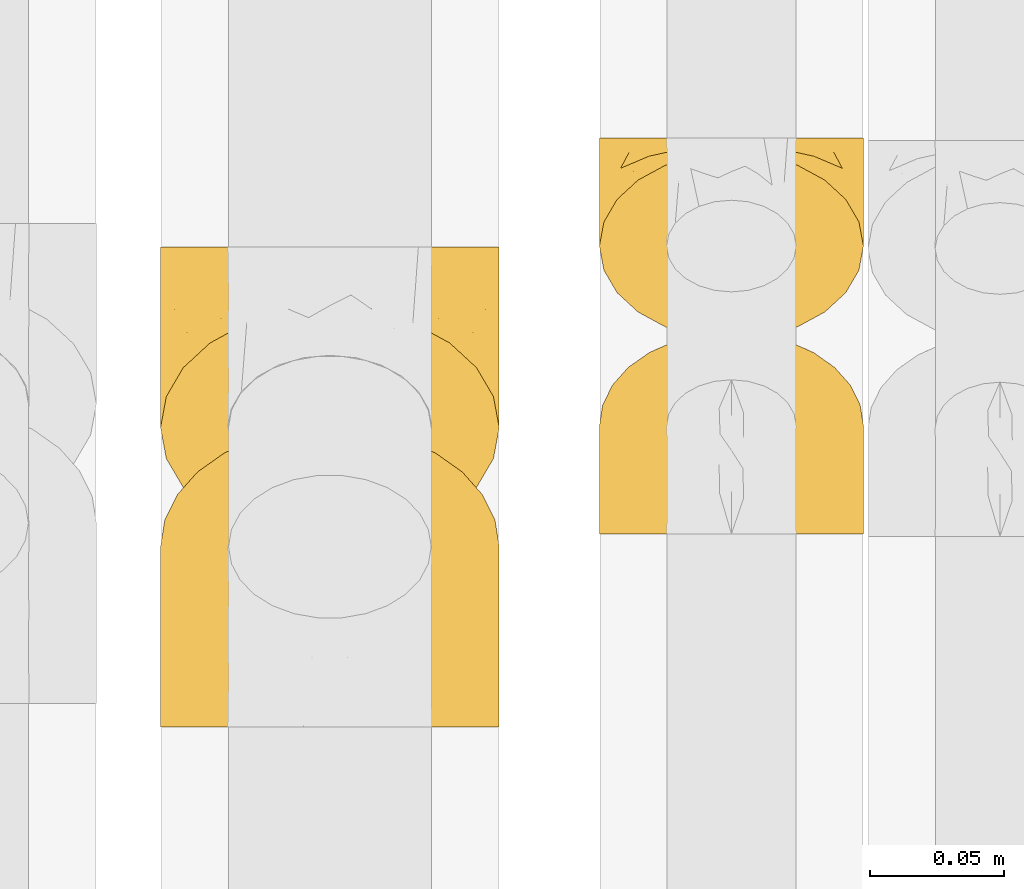
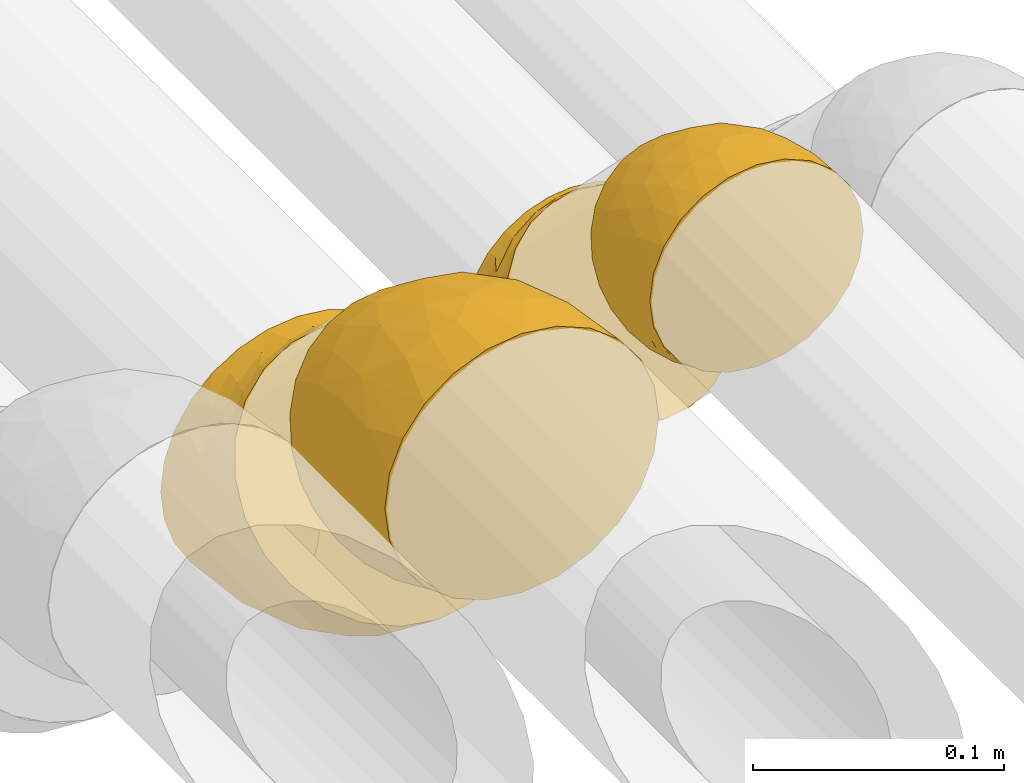
# One storey, part 489 of 827: 4 coverings.
"""IFC2X3 building model written with IfcOpenShell, lengths in millimetres."""

from ifc_helpers import new_model, entity, si_unit, converted_unit, derived_unit, direction, frame, origin, place, context, subcontext, project, spatial, faceted_brep, element, save


model = new_model("IFC2X3")

# Units and contexts
model_context = context("Model", 3, precision=0.01, world=origin(), true_north=direction((6.12303176911189e-17, 1.0)))
body_context = subcontext(model_context, "Body", "Model", "MODEL_VIEW")
ifc_project = project(units=[si_unit("LENGTHUNIT", "METRE", prefix="MILLI"), si_unit("AREAUNIT", "SQUARE_METRE"), si_unit("VOLUMEUNIT", "CUBIC_METRE"), converted_unit("PLANEANGLEUNIT", "DEGREE", entity("IfcRatioMeasure", 0.0174532925199433), si_unit("PLANEANGLEUNIT", "RADIAN"), dimensions=[0, 0, 0, 0, 0, 0, 0]), si_unit("MASSUNIT", "GRAM", prefix="KILO"), derived_unit("MASSDENSITYUNIT", [(si_unit("MASSUNIT", "GRAM", prefix="KILO"), 1), (si_unit("LENGTHUNIT", "METRE"), -3)]), derived_unit("MOMENTOFINERTIAUNIT", [(si_unit("LENGTHUNIT", "METRE"), 4)]), si_unit("TIMEUNIT", "SECOND"), si_unit("FREQUENCYUNIT", "HERTZ"), si_unit("THERMODYNAMICTEMPERATUREUNIT", "DEGREE_CELSIUS"), derived_unit("THERMALTRANSMITTANCEUNIT", [(si_unit("MASSUNIT", "GRAM", prefix="KILO"), 1), (si_unit("THERMODYNAMICTEMPERATUREUNIT", "KELVIN"), -1), (si_unit("TIMEUNIT", "SECOND"), -3)]), derived_unit("VOLUMETRICFLOWRATEUNIT", [(si_unit("LENGTHUNIT", "METRE"), 3), (si_unit("TIMEUNIT", "SECOND"), -1)]), derived_unit("MASSFLOWRATEUNIT", [(si_unit("MASSUNIT", "GRAM", prefix="KILO"), 1), (si_unit("TIMEUNIT", "SECOND"), -1)]), derived_unit("ROTATIONALFREQUENCYUNIT", [(si_unit("TIMEUNIT", "SECOND"), -1)]), si_unit("ELECTRICCURRENTUNIT", "AMPERE"), si_unit("ELECTRICVOLTAGEUNIT", "VOLT"), si_unit("POWERUNIT", "WATT"), si_unit("FORCEUNIT", "NEWTON", prefix="KILO"), si_unit("ILLUMINANCEUNIT", "LUX"), si_unit("LUMINOUSFLUXUNIT", "LUMEN"), si_unit("LUMINOUSINTENSITYUNIT", "CANDELA"), derived_unit("USERDEFINED", [(si_unit("MASSUNIT", "GRAM", prefix="KILO"), -1), (si_unit("LENGTHUNIT", "METRE"), -2), (si_unit("TIMEUNIT", "SECOND"), 3), (si_unit("LUMINOUSFLUXUNIT", "LUMEN"), 1)]), derived_unit("LINEARVELOCITYUNIT", [(si_unit("LENGTHUNIT", "METRE"), 1), (si_unit("TIMEUNIT", "SECOND"), -1)]), si_unit("PRESSUREUNIT", "PASCAL"), derived_unit("USERDEFINED", [(si_unit("LENGTHUNIT", "METRE"), -2), (si_unit("MASSUNIT", "GRAM", prefix="KILO"), 1), (si_unit("TIMEUNIT", "SECOND"), -2)]), derived_unit("LINEARFORCEUNIT", [(si_unit("MASSUNIT", "GRAM", prefix="KILO"), 1), (si_unit("LENGTHUNIT", "METRE"), 1), (si_unit("TIMEUNIT", "SECOND"), -2), (si_unit("LENGTHUNIT", "METRE"), -1)]), derived_unit("PLANARFORCEUNIT", [(si_unit("MASSUNIT", "GRAM", prefix="KILO"), 1), (si_unit("LENGTHUNIT", "METRE"), 1), (si_unit("TIMEUNIT", "SECOND"), -2), (si_unit("LENGTHUNIT", "METRE"), -2)])], contexts=[model_context])

# Site, building, storey
site_placement = place(None, origin())
site = spatial("IfcSite", under=ifc_project, at=site_placement, CompositionType="ELEMENT")
building_placement = place(site_placement, origin())
building = spatial("IfcBuilding", under=site, at=building_placement, CompositionType="ELEMENT")
storey_placement = place(building_placement, frame((0.0, 0.0, 28200.0)))
storey = spatial("IfcBuildingStorey", under=building, at=storey_placement, Name="08", CompositionType="ELEMENT", Elevation=28200.0)

# Coverings
covering_1_placement = place(storey_placement, frame((61001.89, 8152.17, 3046.96)))
element("IfcCovering", 1, at=covering_1_placement, inside=storey, Name=":ADSK_", ObjectType=":ADSK_", PredefinedType="INSULATION", context=body_context, shape_type="Brep", body=[
    faceted_brep([(20.09, 14.73, 9.18), (12.31, 20.24, 14.69), (6.46, 26.83, 21.28), (2.83, 34.17, 28.62), (1.6, 41.9, 36.35), (2.83, 49.64, 44.09), (6.47, 56.99, 51.43), (12.32, 63.57, 58.02), (20.11, 69.08, 63.53), (29.43, 73.22, 67.66), (39.81, 75.78, 70.23), (50.75, 76.65, 71.1), (61.69, 75.78, 70.23), (72.08, 73.21, 67.66), (81.4, 69.07, 63.52), (89.18, 63.56, 58.01), (95.03, 56.97, 51.42), (98.66, 49.63, 44.08), (99.9, 41.9, 36.35), (98.66, 34.16, 28.61), (95.02, 26.82, 21.26), (89.17, 20.23, 14.68), (81.38, 14.72, 9.17), (72.06, 10.59, 5.03), (61.68, 8.02, 2.47), (50.75, 7.15, 1.6), (39.8, 8.02, 2.47), (29.41, 10.59, 5.04), (63.47, 1.6, 5.57), (75.32, 1.6, 10.48), (85.5, 1.6, 18.29), (93.31, 1.6, 28.47), (98.22, 1.6, 40.32), (98.73, 1.6, 44.17), (99.9, 1.6, 53.04), (98.22, 1.6, 65.77), (93.31, 1.6, 77.62), (85.5, 1.6, 87.8), (75.32, 1.6, 95.61), (63.47, 1.6, 100.52), (50.75, 1.6, 102.19), (38.02, 1.6, 100.52), (26.17, 1.6, 95.61), (15.99, 1.6, 87.8), (8.18, 1.6, 77.62), (3.27, 1.6, 65.77), (1.6, 1.6, 53.04), (2.76, 1.6, 44.17), (3.27, 1.6, 40.32), (5.73, 1.6, 34.4), (8.18, 1.6, 28.47), (15.99, 1.6, 18.29), (26.17, 1.6, 10.48), (38.02, 1.6, 5.57), (50.75, 1.6, 3.89), (17.06, 50.76, 74.74), (50.75, 29.07, 98.58), (42.16, 19.13, 99.97), (21.74, 20.34, 90.89), (32.73, 22.35, 96.66), (26.38, 40.28, 87.92), (13.88, 19.78, 83.69), (40.98, 40.29, 93.84), (10.72, 34.98, 74.79), (18.26, 35.02, 83.78), (5.11, 38.13, 61.84), (6.1, 19.63, 71.48), (2.75, 22.22, 60.43), (2.16, 35.73, 50.66), (1.6, 23.41, 48.71), (25.58, 57.96, 77.7), (35.33, 56.93, 83.71), (50.75, 54.67, 87.97), (9.83, 49.84, 65.09), (1.6, 17.92, 49.8), (1.6, 12.43, 50.89), (1.6, 9.72, 51.43), (1.6, 7.01, 51.97), (1.6, 37.31, 39.42), (1.6, 32.71, 42.49), (1.6, 28.06, 45.6), (31.89, 6.25, 6.68), (3.63, 16.23, 36.5), (3.42, 9.32, 39.08), (2.64, 22.66, 37.99), (5.35, 18.11, 30.45), (19.98, 9.02, 13.18), (14.31, 7.35, 19.36), (9.44, 13.47, 23.98), (2.88, 6.24, 41.63), (2.5, 31.3, 33.28), (2.44, 27.55, 36.3), (41.56, 4.74, 4.17), (8.24, 8.06, 27.71), (12.78, 15.85, 17.53), (5.31, 22.07, 28.35), (50.75, 4.6, 3.3), (87.18, 7.35, 19.35), (81.5, 9.01, 13.16), (93.25, 8.06, 27.71), (59.93, 4.74, 4.17), (69.59, 6.25, 6.67), (99.9, 37.31, 39.42), (92.03, 13.46, 23.96), (99.9, 7.01, 51.97), (99.1, 7.26, 43.92), (88.7, 15.84, 17.52), (98.07, 9.32, 39.08), (99.9, 23.41, 48.71), (97.86, 16.24, 36.48), (98.85, 22.65, 37.98), (99.9, 17.92, 49.8), (96.17, 22.05, 28.33), (99.9, 32.71, 42.49), (98.99, 31.3, 33.28), (99.04, 27.55, 36.29), (96.14, 18.09, 30.44), (99.9, 28.06, 45.6), (99.9, 12.43, 50.89), (96.38, 38.12, 61.83), (98.74, 22.22, 60.43), (84.45, 50.76, 74.73), (95.4, 19.61, 71.47), (90.78, 34.97, 74.77), (60.07, 27.94, 97.95), (68.76, 22.36, 96.65), (79.75, 20.34, 90.89), (75.13, 40.28, 87.91), (99.34, 35.73, 50.65), (87.61, 19.78, 83.69), (91.67, 49.83, 65.08), (65.98, 40.09, 92.37), (66.17, 56.93, 83.71), (75.92, 57.95, 77.7), (83.22, 35.02, 83.78)], [[[0, 1, 2, 3, 4, 5, 6, 7, 8, 9, 10, 11, 12, 13, 14, 15, 16, 17, 18, 19, 20, 21, 22, 23, 24, 25, 26, 27]], [[28, 29, 30, 31, 32, 33, 34, 35, 36, 37, 38, 39, 40, 41, 42, 43, 44, 45, 46, 47, 48, 49, 50, 51, 52, 53, 54]], [[7, 55, 8]], [[40, 56, 57]], [[42, 58, 43]], [[59, 60, 58]], [[61, 44, 43]], [[60, 59, 62]], [[63, 61, 64]], [[63, 65, 66]], [[67, 46, 45]], [[66, 67, 45]], [[42, 41, 59]], [[67, 68, 69]], [[58, 61, 43]], [[70, 60, 71]], [[71, 62, 72]], [[72, 10, 71]], [[55, 70, 8]], [[9, 70, 71]], [[59, 58, 42]], [[11, 10, 72]], [[73, 55, 7]], [[67, 69, 74, 75, 76, 77, 46]], [[41, 57, 59]], [[68, 4, 78, 79, 80, 69]], [[6, 5, 65]], [[73, 65, 63]], [[45, 44, 66]], [[67, 66, 65]], [[6, 73, 7]], [[57, 62, 59]], [[68, 65, 5]], [[9, 71, 10]], [[60, 55, 64]], [[66, 44, 61]], [[64, 61, 58]], [[61, 63, 66]], [[60, 64, 58]], [[63, 64, 55]], [[65, 73, 6]], [[55, 73, 63]], [[65, 68, 67]], [[4, 68, 5]], [[8, 70, 9]], [[55, 60, 70]], [[40, 57, 41]], [[62, 57, 56]], [[72, 62, 56]], [[62, 71, 60]], [[52, 81, 53]], [[82, 83, 74]], [[84, 85, 82]], [[86, 87, 88]], [[77, 89, 48]], [[87, 52, 51]], [[90, 2, 91]], [[92, 26, 25]], [[86, 27, 81]], [[54, 53, 92]], [[52, 86, 81]], [[93, 51, 50]], [[87, 51, 93]], [[83, 93, 50]], [[94, 95, 1]], [[2, 1, 95]], [[2, 95, 91]], [[4, 3, 78]], [[94, 88, 85]], [[86, 94, 0]], [[48, 47, 46, 77]], [[96, 92, 25]], [[80, 91, 84]], [[27, 26, 81]], [[0, 27, 86]], [[90, 78, 3]], [[26, 92, 81]], [[94, 86, 88]], [[82, 93, 83]], [[0, 94, 1]], [[80, 84, 69]], [[82, 88, 93]], [[49, 48, 89]], [[69, 82, 74]], [[83, 75, 74]], [[88, 87, 93]], [[52, 87, 86]], [[91, 80, 79]], [[91, 79, 90]], [[84, 91, 95]], [[85, 84, 95]], [[69, 84, 82]], [[78, 90, 79]], [[2, 90, 3]], [[94, 85, 95]], [[82, 85, 88]], [[54, 92, 96]], [[81, 92, 53]], [[83, 89, 75]], [[77, 76, 75, 89]], [[83, 49, 89]], [[83, 50, 49]], [[97, 29, 98]], [[30, 99, 31]], [[100, 101, 28]], [[19, 18, 102]], [[103, 99, 97]], [[101, 29, 28]], [[104, 33, 105]], [[98, 106, 103]], [[107, 31, 99]], [[97, 99, 30]], [[108, 109, 110]], [[23, 98, 101]], [[54, 96, 100]], [[109, 111, 107]], [[25, 24, 100]], [[112, 106, 21]], [[101, 24, 23]], [[102, 113, 114]], [[105, 31, 107]], [[22, 98, 23]], [[21, 106, 22]], [[112, 21, 20]], [[106, 98, 22]], [[20, 19, 114]], [[112, 115, 110]], [[113, 115, 114]], [[29, 101, 98]], [[112, 116, 106]], [[29, 97, 30]], [[96, 25, 100]], [[115, 113, 117]], [[103, 109, 99]], [[109, 107, 99]], [[105, 107, 118]], [[111, 109, 108]], [[111, 118, 107]], [[103, 97, 98]], [[110, 116, 112]], [[110, 115, 117]], [[20, 115, 112]], [[108, 110, 117]], [[116, 109, 103]], [[20, 114, 115]], [[102, 114, 19]], [[109, 116, 110]], [[106, 116, 103]], [[104, 34, 33]], [[33, 32, 105]], [[101, 100, 24]], [[54, 100, 28]], [[104, 105, 118]], [[31, 105, 32]], [[17, 16, 119]], [[35, 34, 120]], [[120, 34, 104, 118, 111, 108]], [[121, 15, 14]], [[36, 35, 122]], [[122, 119, 123]], [[39, 124, 40]], [[125, 126, 127]], [[125, 39, 38]], [[128, 120, 108]], [[129, 36, 122]], [[38, 126, 125]], [[129, 126, 37]], [[37, 126, 38]], [[120, 128, 119]], [[35, 120, 122]], [[119, 16, 130]], [[131, 127, 132]], [[130, 16, 15]], [[133, 14, 13]], [[134, 127, 126]], [[123, 130, 121]], [[125, 127, 131]], [[13, 132, 133]], [[12, 11, 72]], [[72, 56, 124]], [[12, 72, 132]], [[133, 132, 127]], [[123, 129, 122]], [[12, 132, 13]], [[119, 122, 120]], [[128, 18, 17]], [[39, 125, 124]], [[126, 129, 134]], [[36, 129, 37]], [[134, 123, 121]], [[123, 134, 129]], [[127, 134, 121]], [[121, 130, 15]], [[119, 130, 123]], [[128, 108, 117, 113, 102, 18]], [[119, 128, 17]], [[127, 121, 133]], [[14, 133, 121]], [[72, 131, 132]], [[124, 125, 131]], [[72, 124, 131]], [[124, 56, 40]]]),
])
covering_2_placement = place(storey_placement, frame((61001.89, 8224.59, 2949.0)))
element("IfcCovering", 2, at=covering_2_placement, inside=storey, Name=":ADSK_", ObjectType=":ADSK_", PredefinedType="INSULATION", context=body_context, shape_type="Brep", body=[
    faceted_brep([(61.69, 76.65, 98.66), (72.08, 76.65, 95.02), (81.4, 76.65, 89.17), (89.18, 76.65, 81.38), (95.03, 76.65, 72.06), (98.66, 76.65, 61.68), (99.9, 76.65, 50.75), (98.66, 76.65, 39.8), (95.02, 76.65, 29.41), (89.17, 76.65, 20.09), (81.38, 76.65, 12.31), (72.06, 76.65, 6.46), (61.68, 76.65, 2.83), (50.75, 76.65, 1.6), (39.8, 76.65, 2.83), (29.41, 76.65, 6.47), (20.09, 76.65, 12.32), (12.31, 76.65, 20.11), (6.46, 76.65, 29.43), (2.83, 76.65, 39.81), (1.6, 76.65, 50.75), (2.83, 76.65, 61.69), (6.47, 76.65, 72.08), (12.32, 76.65, 81.4), (20.11, 76.65, 89.18), (29.43, 76.65, 95.03), (39.81, 76.65, 98.66), (50.75, 76.65, 99.9), (38.02, 69.92, 101.01), (26.17, 66.45, 97.54), (15.99, 60.92, 92.02), (8.18, 53.73, 84.82), (3.27, 45.34, 76.44), (2.76, 42.63, 73.72), (1.6, 36.35, 67.44), (3.27, 27.35, 58.45), (8.18, 18.97, 50.06), (15.99, 11.77, 42.87), (26.17, 6.25, 37.34), (38.02, 2.78, 33.87), (50.75, 1.6, 32.69), (63.47, 2.78, 33.87), (75.32, 6.25, 37.34), (85.5, 11.77, 42.87), (93.31, 18.97, 50.06), (98.22, 27.35, 58.45), (99.9, 36.35, 67.44), (98.73, 42.63, 73.72), (98.22, 45.34, 76.44), (95.77, 49.54, 80.63), (93.31, 53.73, 84.82), (85.5, 60.92, 92.02), (75.32, 66.45, 97.54), (63.47, 69.92, 101.01), (50.75, 71.1, 102.19), (84.43, 55.78, 17.34), (50.75, 23.58, 15.82), (59.33, 15.57, 21.86), (79.75, 22.85, 27.43), (68.76, 20.19, 21.92), (75.11, 39.05, 15.43), (87.61, 27.54, 32.91), (60.52, 34.86, 11.24), (90.77, 44.58, 28.46), (83.23, 38.25, 22.07), (96.38, 55.96, 35.39), (95.39, 36.06, 41.65), (98.74, 45.71, 47.63), (99.33, 62.18, 44.99), (99.9, 54.84, 55.08), (75.91, 58.77, 10.15), (66.16, 53.8, 6.63), (50.75, 49.18, 5.21), (91.66, 61.94, 24.81), (99.9, 50.19, 58.19), (99.9, 45.54, 61.3), (99.9, 43.24, 62.84), (99.9, 40.94, 64.37), (99.9, 71.24, 51.82), (99.9, 65.82, 52.9), (99.9, 60.33, 53.99), (69.6, 72.43, 96.93), (97.86, 58.4, 68.79), (98.07, 51.68, 71.85), (98.85, 61.89, 63.19), (96.14, 64.0, 71.74), (81.51, 69.79, 90.38), (87.18, 64.24, 87.19), (92.05, 65.3, 79.59), (98.61, 47.71, 72.23), (98.99, 71.33, 60.42), (99.05, 66.54, 60.92), (59.93, 73.13, 99.77), (93.25, 58.83, 80.78), (88.71, 71.54, 82.47), (96.18, 68.29, 70.43), (50.75, 73.65, 100.49), (14.31, 64.24, 87.19), (19.99, 69.79, 90.39), (8.24, 58.83, 80.78), (41.56, 73.13, 99.78), (31.91, 72.43, 96.94), (1.6, 71.24, 51.82), (9.46, 65.31, 79.62), (1.6, 40.94, 64.37), (2.39, 46.81, 69.89), (12.79, 71.54, 82.49), (3.42, 51.68, 71.85), (1.6, 54.84, 55.08), (3.63, 58.41, 68.8), (2.64, 61.89, 63.2), (1.6, 50.19, 58.19), (5.32, 68.29, 70.45), (1.6, 65.82, 52.9), (2.5, 71.32, 60.41), (2.45, 66.55, 60.94), (5.35, 64.0, 71.76), (1.6, 60.33, 53.99), (1.6, 45.54, 61.3), (5.11, 55.96, 35.4), (2.75, 45.71, 47.64), (17.04, 55.78, 17.35), (6.1, 36.06, 41.67), (10.71, 44.59, 28.47), (41.42, 23.23, 17.06), (32.73, 20.2, 21.92), (21.74, 22.84, 27.43), (26.36, 39.05, 15.44), (2.16, 62.18, 44.99), (13.88, 27.54, 32.91), (9.82, 61.95, 24.82), (35.51, 35.76, 12.42), (35.32, 53.79, 6.63), (25.57, 58.77, 10.16), (18.27, 38.25, 22.07)], [[[0, 1, 2, 3, 4, 5, 6, 7, 8, 9, 10, 11, 12, 13, 14, 15, 16, 17, 18, 19, 20, 21, 22, 23, 24, 25, 26, 27]], [[28, 29, 30, 31, 32, 33, 34, 35, 36, 37, 38, 39, 40, 41, 42, 43, 44, 45, 46, 47, 48, 49, 50, 51, 52, 53, 54]], [[9, 55, 10]], [[40, 56, 57]], [[42, 58, 43]], [[59, 60, 58]], [[61, 44, 43]], [[60, 59, 62]], [[63, 61, 64]], [[63, 65, 66]], [[67, 46, 45]], [[66, 67, 45]], [[42, 41, 59]], [[67, 68, 69]], [[58, 61, 43]], [[70, 60, 71]], [[71, 62, 72]], [[72, 12, 71]], [[55, 70, 10]], [[11, 70, 71]], [[59, 58, 42]], [[13, 12, 72]], [[73, 55, 9]], [[67, 69, 74, 75, 76, 77, 46]], [[41, 57, 59]], [[68, 6, 78, 79, 80, 69]], [[8, 7, 65]], [[73, 65, 63]], [[45, 44, 66]], [[67, 66, 65]], [[8, 73, 9]], [[57, 62, 59]], [[68, 65, 7]], [[11, 71, 12]], [[60, 55, 64]], [[66, 44, 61]], [[64, 61, 58]], [[61, 63, 66]], [[60, 64, 58]], [[63, 64, 55]], [[65, 73, 8]], [[55, 73, 63]], [[65, 68, 67]], [[6, 68, 7]], [[10, 70, 11]], [[55, 60, 70]], [[40, 57, 41]], [[62, 57, 56]], [[72, 62, 56]], [[62, 71, 60]], [[52, 81, 53]], [[82, 83, 74]], [[84, 85, 82]], [[86, 87, 88]], [[77, 89, 48]], [[87, 52, 51]], [[90, 4, 91]], [[92, 0, 27]], [[86, 1, 81]], [[54, 53, 92]], [[52, 86, 81]], [[93, 51, 50]], [[87, 51, 93]], [[83, 93, 50]], [[94, 95, 3]], [[4, 3, 95]], [[4, 95, 91]], [[6, 5, 78]], [[94, 88, 85]], [[86, 94, 2]], [[48, 47, 46, 77]], [[96, 92, 27]], [[80, 91, 84]], [[1, 0, 81]], [[2, 1, 86]], [[90, 78, 5]], [[0, 92, 81]], [[94, 86, 88]], [[82, 93, 83]], [[2, 94, 3]], [[80, 84, 69]], [[82, 88, 93]], [[49, 48, 89]], [[69, 82, 74]], [[83, 75, 74]], [[88, 87, 93]], [[52, 87, 86]], [[91, 80, 79]], [[91, 79, 90]], [[84, 91, 95]], [[85, 84, 95]], [[69, 84, 82]], [[78, 90, 79]], [[4, 90, 5]], [[94, 85, 95]], [[82, 85, 88]], [[54, 92, 96]], [[81, 92, 53]], [[83, 89, 75]], [[77, 76, 75, 89]], [[83, 49, 89]], [[83, 50, 49]], [[97, 29, 98]], [[30, 99, 31]], [[100, 101, 28]], [[21, 20, 102]], [[103, 99, 97]], [[101, 29, 28]], [[104, 33, 105]], [[98, 106, 103]], [[107, 31, 99]], [[97, 99, 30]], [[108, 109, 110]], [[25, 98, 101]], [[54, 96, 100]], [[109, 111, 107]], [[27, 26, 100]], [[112, 106, 23]], [[101, 26, 25]], [[102, 113, 114]], [[105, 31, 107]], [[24, 98, 25]], [[23, 106, 24]], [[112, 23, 22]], [[106, 98, 24]], [[22, 21, 114]], [[112, 115, 110]], [[113, 115, 114]], [[29, 101, 98]], [[112, 116, 106]], [[29, 97, 30]], [[96, 27, 100]], [[115, 113, 117]], [[103, 109, 99]], [[109, 107, 99]], [[105, 107, 118]], [[111, 109, 108]], [[111, 118, 107]], [[103, 97, 98]], [[110, 116, 112]], [[110, 115, 117]], [[22, 115, 112]], [[108, 110, 117]], [[116, 109, 103]], [[22, 114, 115]], [[102, 114, 21]], [[109, 116, 110]], [[106, 116, 103]], [[104, 34, 33]], [[33, 32, 105]], [[101, 100, 26]], [[54, 100, 28]], [[104, 105, 118]], [[31, 105, 32]], [[19, 18, 119]], [[35, 34, 120]], [[120, 34, 104, 118, 111, 108]], [[121, 17, 16]], [[36, 35, 122]], [[122, 119, 123]], [[39, 124, 40]], [[125, 126, 127]], [[125, 39, 38]], [[128, 120, 108]], [[129, 36, 122]], [[38, 126, 125]], [[129, 126, 37]], [[37, 126, 38]], [[120, 128, 119]], [[35, 120, 122]], [[119, 18, 130]], [[131, 127, 132]], [[130, 18, 17]], [[133, 16, 15]], [[134, 127, 126]], [[123, 130, 121]], [[125, 127, 131]], [[15, 132, 133]], [[14, 13, 72]], [[72, 56, 124]], [[14, 72, 132]], [[133, 132, 127]], [[123, 129, 122]], [[14, 132, 15]], [[119, 122, 120]], [[128, 20, 19]], [[39, 125, 124]], [[126, 129, 134]], [[36, 129, 37]], [[134, 123, 121]], [[123, 134, 129]], [[127, 134, 121]], [[121, 130, 17]], [[119, 130, 123]], [[128, 108, 117, 113, 102, 20]], [[119, 128, 19]], [[127, 121, 133]], [[16, 133, 121]], [[72, 131, 132]], [[124, 125, 131]], [[72, 124, 131]], [[124, 56, 40]]]),
])
covering_3_placement = place(storey_placement, frame((60838.46, 8080.24, 3026.0)))
element("IfcCovering", 3, at=covering_3_placement, inside=storey, Name=":ADSK_", ObjectType=":ADSK_", PredefinedType="INSULATION", context=body_context, shape_type="Brep", body=[
    faceted_brep([(50.62, 25.31, 2.71), (37.29, 28.6, 6.01), (25.34, 33.91, 11.32), (15.35, 40.97, 18.38), (7.84, 49.42, 26.83), (3.18, 58.85, 36.25), (1.6, 68.77, 46.18), (3.18, 78.69, 56.1), (7.84, 88.11, 65.52), (15.35, 96.57, 73.97), (25.33, 103.63, 81.03), (37.29, 108.94, 86.35), (50.61, 112.24, 89.64), (64.65, 113.35, 90.76), (78.67, 112.24, 89.64), (92.0, 108.94, 86.35), (103.95, 103.63, 81.04), (113.94, 96.57, 73.98), (121.45, 88.12, 65.52), (126.11, 78.69, 56.1), (127.7, 68.77, 46.18), (126.11, 58.85, 36.26), (121.45, 49.43, 26.84), (113.94, 40.97, 18.38), (103.96, 33.92, 11.32), (92.0, 28.6, 6.01), (78.68, 25.31, 2.71), (64.65, 24.19, 1.6), (64.65, 1.6, 10.95), (80.96, 1.6, 13.1), (96.17, 1.6, 19.4), (109.23, 1.6, 29.42), (119.25, 1.6, 42.48), (125.55, 1.6, 57.68), (127.7, 1.6, 74.0), (125.55, 1.6, 90.32), (119.25, 1.6, 105.53), (109.23, 1.6, 118.59), (96.17, 1.6, 128.61), (80.96, 1.6, 134.9), (64.65, 1.6, 137.05), (48.33, 1.6, 134.9), (33.12, 1.6, 128.61), (20.06, 1.6, 118.59), (10.04, 1.6, 105.53), (3.74, 1.6, 90.32), (1.6, 1.6, 74.0), (3.74, 1.6, 57.68), (10.04, 1.6, 42.48), (20.06, 1.6, 29.42), (33.12, 1.6, 19.4), (48.33, 1.6, 13.1), (21.19, 76.62, 98.01), (64.65, 42.5, 131.67), (49.11, 26.3, 133.14), (27.24, 29.71, 122.02), (64.65, 80.62, 115.88), (48.02, 50.14, 127.07), (4.56, 45.26, 84.43), (7.03, 24.26, 97.47), (44.69, 83.89, 110.13), (16.27, 46.82, 106.67), (1.6, 26.18, 70.77), (1.6, 14.06, 72.36), (31.97, 86.37, 101.44), (33.0, 59.65, 116.8), (12.17, 72.58, 87.85), (38.77, 29.0, 129.02), (1.6, 58.8, 53.83), (1.6, 49.1, 61.28), (1.6, 37.64, 66.02), (9.41, 49.29, 94.98), (9.03, 39.61, 32.09), (3.39, 48.21, 44.09), (4.2, 15.95, 54.72), (11.35, 16.09, 38.57), (16.97, 29.59, 24.87), (6.76, 31.99, 42.06), (27.09, 19.03, 19.79), (24.13, 10.06, 24.92), (17.71, 19.8, 28.68), (29.31, 26.24, 13.97), (54.87, 8.8, 10.91), (41.52, 17.76, 11.55), (53.31, 17.63, 7.82), (2.7, 39.18, 53.26), (3.68, 27.59, 53.51), (38.92, 9.04, 15.69), (64.65, 13.82, 8.52), (87.78, 17.76, 11.56), (112.32, 29.6, 24.87), (77.22, 11.06, 10.84), (117.94, 16.09, 38.57), (125.09, 15.95, 54.72), (93.94, 10.88, 17.05), (102.2, 19.03, 19.79), (127.7, 14.06, 72.36), (126.59, 39.18, 53.26), (127.7, 49.1, 61.28), (127.7, 37.64, 66.02), (120.26, 39.62, 32.09), (122.53, 31.99, 42.06), (126.43, 28.3, 56.99), (123.17, 21.87, 47.6), (105.16, 10.06, 24.92), (111.59, 19.8, 28.68), (125.9, 48.21, 44.09), (99.98, 26.24, 13.97), (127.7, 58.8, 53.83), (127.7, 26.18, 70.77), (124.73, 45.26, 84.43), (122.26, 24.26, 97.47), (108.1, 76.62, 98.01), (113.02, 46.83, 106.66), (117.12, 72.59, 87.85), (97.32, 86.37, 101.44), (96.29, 59.65, 116.81), (102.05, 29.71, 122.02), (80.18, 26.31, 133.14), (90.52, 29.0, 129.02), (84.6, 83.89, 110.13), (81.27, 50.14, 127.07), (119.88, 49.29, 94.98)], [[[0, 1, 2, 3, 4, 5, 6, 7, 8, 9, 10, 11, 12, 13, 14, 15, 16, 17, 18, 19, 20, 21, 22, 23, 24, 25, 26, 27]], [[28, 29, 30, 31, 32, 33, 34, 35, 36, 37, 38, 39, 40, 41, 42, 43, 44, 45, 46, 47, 48, 49, 50, 51]], [[52, 10, 9]], [[40, 53, 54]], [[42, 55, 43]], [[53, 56, 57]], [[8, 7, 58]], [[45, 59, 58]], [[56, 12, 60]], [[61, 44, 43]], [[45, 62, 63, 46]], [[62, 45, 58]], [[59, 45, 44]], [[64, 52, 65]], [[55, 61, 43]], [[61, 65, 52]], [[60, 57, 56]], [[60, 65, 57]], [[52, 9, 66]], [[64, 11, 10]], [[64, 60, 11]], [[12, 56, 13]], [[61, 55, 65]], [[67, 55, 42]], [[54, 67, 41]], [[61, 52, 66]], [[66, 9, 8]], [[7, 6, 68, 69]], [[58, 69, 70, 62]], [[58, 7, 69]], [[60, 64, 65]], [[52, 64, 10]], [[58, 59, 71]], [[54, 57, 67]], [[58, 66, 8]], [[60, 12, 11]], [[41, 67, 42]], [[65, 55, 67]], [[65, 67, 57]], [[40, 54, 41]], [[53, 57, 54]], [[44, 61, 59]], [[58, 71, 66]], [[59, 61, 71]], [[61, 66, 71]], [[72, 73, 4]], [[62, 74, 63]], [[48, 75, 49]], [[63, 74, 47]], [[75, 48, 74]], [[72, 76, 77]], [[78, 79, 80]], [[81, 2, 1]], [[82, 28, 51]], [[83, 84, 82]], [[73, 77, 85]], [[86, 62, 70]], [[83, 87, 78]], [[50, 87, 51]], [[86, 75, 74]], [[68, 73, 69]], [[4, 3, 72]], [[73, 5, 4]], [[74, 48, 47]], [[73, 68, 5]], [[80, 77, 76]], [[69, 85, 70]], [[81, 76, 2]], [[88, 84, 27]], [[84, 83, 0]], [[0, 83, 1]], [[2, 76, 3]], [[50, 49, 79]], [[83, 78, 81]], [[80, 76, 78]], [[73, 72, 77]], [[76, 72, 3]], [[85, 86, 70]], [[68, 6, 5]], [[73, 85, 69]], [[86, 85, 77]], [[75, 86, 77]], [[86, 74, 62]], [[47, 46, 63]], [[83, 81, 1]], [[76, 81, 78]], [[75, 79, 49]], [[87, 79, 78]], [[79, 75, 80]], [[77, 80, 75]], [[27, 84, 0]], [[82, 84, 88]], [[28, 82, 88]], [[82, 51, 87]], [[87, 50, 79]], [[82, 87, 83]], [[26, 25, 89]], [[24, 23, 90]], [[88, 91, 28]], [[32, 92, 93]], [[94, 89, 95]], [[94, 29, 91]], [[93, 96, 33]], [[97, 98, 99]], [[23, 22, 100]], [[101, 102, 103]], [[104, 95, 105]], [[93, 33, 32]], [[100, 90, 23]], [[102, 97, 99]], [[91, 26, 89]], [[97, 106, 98]], [[25, 107, 89]], [[93, 92, 103]], [[90, 95, 107]], [[31, 92, 32]], [[31, 30, 104]], [[107, 25, 24]], [[22, 21, 106]], [[101, 97, 102]], [[89, 94, 91]], [[31, 104, 92]], [[98, 106, 108]], [[106, 21, 108]], [[100, 106, 101]], [[101, 92, 105]], [[106, 100, 22]], [[26, 88, 27]], [[90, 100, 101]], [[21, 20, 108]], [[93, 102, 109]], [[106, 97, 101]], [[109, 102, 99]], [[102, 93, 103]], [[96, 93, 109]], [[96, 34, 33]], [[101, 103, 92]], [[90, 107, 24]], [[89, 107, 95]], [[94, 104, 30]], [[95, 90, 105]], [[101, 105, 90]], [[92, 104, 105]], [[104, 94, 95]], [[29, 94, 30]], [[28, 91, 29]], [[26, 91, 88]], [[35, 110, 111]], [[112, 113, 114]], [[35, 34, 96, 109]], [[112, 114, 17]], [[112, 115, 116]], [[117, 113, 116]], [[39, 118, 40]], [[116, 119, 117]], [[120, 121, 116]], [[113, 117, 37]], [[36, 113, 37]], [[38, 117, 119]], [[119, 116, 121]], [[19, 18, 110]], [[110, 109, 99, 98]], [[122, 111, 110]], [[19, 98, 108, 20]], [[37, 117, 38]], [[112, 17, 16]], [[39, 119, 118]], [[116, 113, 112]], [[110, 35, 109]], [[119, 39, 38]], [[114, 18, 17]], [[121, 120, 56]], [[115, 16, 15]], [[14, 13, 56]], [[14, 56, 120]], [[110, 18, 114]], [[115, 120, 116]], [[121, 56, 53]], [[14, 120, 15]], [[115, 112, 16]], [[19, 110, 98]], [[120, 115, 15]], [[35, 111, 36]], [[119, 121, 118]], [[121, 53, 118]], [[40, 118, 53]], [[122, 110, 114]], [[113, 36, 111]], [[114, 113, 122]], [[113, 111, 122]]]),
])
covering_4_placement = place(storey_placement, frame((60838.46, 8147.18, 2935.35)))
element("IfcCovering", 4, at=covering_4_placement, inside=storey, Name=":ADSK_", ObjectType=":ADSK_", PredefinedType="INSULATION", context=body_context, shape_type="Brep", body=[
    faceted_brep([(64.65, 113.35, 127.7), (78.67, 113.35, 126.11), (92.0, 113.35, 121.45), (103.95, 113.35, 113.94), (113.94, 113.35, 103.96), (121.45, 113.35, 92.0), (126.11, 113.35, 78.68), (127.7, 113.35, 64.65), (126.11, 113.35, 50.62), (121.45, 113.35, 37.29), (113.94, 113.35, 25.34), (103.96, 113.35, 15.35), (92.0, 113.35, 7.84), (78.68, 113.35, 3.18), (64.65, 113.35, 1.6), (50.62, 113.35, 3.18), (37.29, 113.35, 7.84), (25.34, 113.35, 15.35), (15.35, 113.35, 25.33), (7.84, 113.35, 37.29), (3.18, 113.35, 50.61), (1.6, 113.35, 64.65), (3.18, 113.35, 78.67), (7.84, 113.35, 92.0), (15.35, 113.35, 103.95), (25.33, 113.35, 113.94), (37.29, 113.35, 121.45), (50.61, 113.35, 126.11), (64.65, 90.76, 137.05), (48.33, 89.24, 135.53), (33.12, 84.79, 131.08), (20.06, 77.7, 124.0), (10.04, 68.47, 114.76), (3.74, 57.72, 104.01), (1.6, 46.18, 92.47), (3.74, 34.64, 80.93), (10.04, 23.89, 70.18), (20.06, 14.65, 60.95), (33.12, 7.57, 53.86), (48.33, 3.11, 49.41), (64.65, 1.6, 47.89), (80.96, 3.11, 49.41), (96.17, 7.57, 53.86), (109.23, 14.65, 60.95), (119.25, 23.89, 70.18), (125.55, 34.64, 80.93), (127.7, 46.18, 92.47), (125.55, 57.72, 104.01), (119.25, 68.47, 114.76), (109.23, 77.7, 124.0), (96.17, 84.79, 131.08), (80.96, 89.24, 135.53), (108.1, 82.25, 22.45), (64.65, 34.33, 22.77), (80.19, 21.83, 33.18), (102.05, 32.11, 38.64), (64.65, 72.45, 6.98), (81.27, 42.98, 20.62), (124.73, 69.69, 54.22), (122.26, 45.61, 59.86), (84.6, 78.83, 8.74), (113.02, 55.06, 37.39), (127.7, 65.85, 77.37), (127.7, 56.15, 84.82), (97.32, 86.72, 13.12), (96.3, 56.96, 21.15), (117.12, 86.58, 32.48), (90.52, 26.66, 34.19), (127.7, 100.89, 66.29), (127.7, 88.77, 67.88), (127.7, 77.31, 72.63), (119.88, 65.07, 43.92), (120.26, 102.7, 95.22), (125.9, 100.29, 80.66), (125.09, 69.96, 95.96), (117.94, 81.48, 107.27), (112.32, 100.72, 107.42), (122.53, 90.26, 93.57), (102.2, 96.84, 118.48), (105.16, 86.87, 121.19), (111.58, 91.1, 111.65), (99.98, 106.05, 117.49), (74.42, 95.88, 131.99), (87.77, 101.77, 125.2), (75.98, 104.32, 127.93), (126.59, 87.42, 80.56), (125.61, 79.05, 88.58), (90.37, 92.68, 128.43), (64.65, 101.13, 130.13), (41.51, 101.77, 125.19), (16.97, 100.72, 107.41), (52.07, 97.53, 130.44), (11.35, 81.48, 107.27), (4.2, 69.96, 95.96), (35.35, 93.01, 126.18), (27.09, 96.84, 118.48), (1.6, 56.15, 84.82), (2.7, 87.42, 80.56), (1.6, 88.77, 67.88), (1.6, 77.31, 72.63), (9.03, 102.7, 95.22), (6.76, 90.26, 93.56), (2.86, 77.09, 85.62), (6.13, 79.18, 96.8), (24.13, 86.87, 121.19), (17.7, 91.09, 111.65), (3.39, 100.29, 80.66), (29.31, 106.05, 117.49), (1.6, 100.89, 66.29), (1.6, 65.85, 77.37), (4.56, 69.69, 54.22), (7.03, 45.61, 59.86), (21.19, 82.25, 22.44), (16.27, 55.07, 37.39), (12.17, 86.58, 32.48), (31.97, 86.72, 13.12), (33.0, 56.96, 21.15), (27.24, 32.11, 38.63), (49.11, 21.84, 33.18), (38.77, 26.66, 34.19), (44.69, 78.83, 8.73), (48.02, 42.98, 20.62), (9.41, 65.07, 43.91)], [[[0, 1, 2, 3, 4, 5, 6, 7, 8, 9, 10, 11, 12, 13, 14, 15, 16, 17, 18, 19, 20, 21, 22, 23, 24, 25, 26, 27]], [[28, 29, 30, 31, 32, 33, 34, 35, 36, 37, 38, 39, 40, 41, 42, 43, 44, 45, 46, 47, 48, 49, 50, 51]], [[52, 11, 10]], [[40, 53, 54]], [[42, 55, 43]], [[53, 56, 57]], [[9, 8, 58]], [[45, 59, 58]], [[56, 13, 60]], [[61, 44, 43]], [[45, 62, 63, 46]], [[62, 45, 58]], [[59, 45, 44]], [[64, 52, 65]], [[55, 61, 43]], [[61, 65, 52]], [[60, 57, 56]], [[60, 65, 57]], [[52, 10, 66]], [[64, 12, 11]], [[64, 60, 12]], [[13, 56, 14]], [[61, 55, 65]], [[67, 55, 42]], [[54, 67, 41]], [[61, 52, 66]], [[66, 10, 9]], [[8, 7, 68, 69]], [[58, 69, 70, 62]], [[58, 8, 69]], [[60, 64, 65]], [[52, 64, 11]], [[58, 59, 71]], [[54, 57, 67]], [[58, 66, 9]], [[60, 13, 12]], [[41, 67, 42]], [[65, 55, 67]], [[65, 67, 57]], [[40, 54, 41]], [[53, 57, 54]], [[44, 61, 59]], [[58, 71, 66]], [[59, 61, 71]], [[61, 66, 71]], [[72, 73, 5]], [[62, 74, 63]], [[48, 75, 49]], [[63, 74, 47]], [[75, 48, 74]], [[72, 76, 77]], [[78, 79, 80]], [[81, 3, 2]], [[82, 28, 51]], [[83, 84, 82]], [[73, 77, 85]], [[86, 62, 70]], [[83, 87, 78]], [[50, 87, 51]], [[86, 75, 74]], [[68, 73, 69]], [[5, 4, 72]], [[73, 6, 5]], [[74, 48, 47]], [[73, 68, 6]], [[80, 77, 76]], [[69, 85, 70]], [[81, 76, 3]], [[88, 84, 0]], [[84, 83, 1]], [[1, 83, 2]], [[3, 76, 4]], [[50, 49, 79]], [[83, 78, 81]], [[80, 76, 78]], [[73, 72, 77]], [[76, 72, 4]], [[85, 86, 70]], [[68, 7, 6]], [[73, 85, 69]], [[86, 85, 77]], [[75, 86, 77]], [[86, 74, 62]], [[47, 46, 63]], [[83, 81, 2]], [[76, 81, 78]], [[75, 79, 49]], [[87, 79, 78]], [[79, 75, 80]], [[77, 80, 75]], [[0, 84, 1]], [[82, 84, 88]], [[28, 82, 88]], [[82, 51, 87]], [[87, 50, 79]], [[82, 87, 83]], [[27, 26, 89]], [[25, 24, 90]], [[88, 91, 28]], [[32, 92, 93]], [[94, 89, 95]], [[94, 29, 91]], [[93, 96, 33]], [[97, 98, 99]], [[24, 23, 100]], [[101, 102, 103]], [[104, 95, 105]], [[93, 33, 32]], [[100, 90, 24]], [[102, 97, 99]], [[91, 27, 89]], [[97, 106, 98]], [[26, 107, 89]], [[93, 92, 103]], [[90, 95, 107]], [[31, 92, 32]], [[31, 30, 104]], [[107, 26, 25]], [[23, 22, 106]], [[101, 97, 102]], [[89, 94, 91]], [[31, 104, 92]], [[98, 106, 108]], [[106, 22, 108]], [[100, 106, 101]], [[101, 92, 105]], [[106, 100, 23]], [[27, 88, 0]], [[90, 100, 101]], [[22, 21, 108]], [[93, 102, 109]], [[106, 97, 101]], [[109, 102, 99]], [[102, 93, 103]], [[96, 93, 109]], [[96, 34, 33]], [[101, 103, 92]], [[90, 107, 25]], [[89, 107, 95]], [[94, 104, 30]], [[95, 90, 105]], [[101, 105, 90]], [[92, 104, 105]], [[104, 94, 95]], [[29, 94, 30]], [[28, 91, 29]], [[27, 91, 88]], [[35, 110, 111]], [[112, 113, 114]], [[35, 34, 96, 109]], [[112, 114, 18]], [[112, 115, 116]], [[117, 113, 116]], [[39, 118, 40]], [[116, 119, 117]], [[120, 121, 116]], [[113, 117, 37]], [[36, 113, 37]], [[38, 117, 119]], [[119, 116, 121]], [[20, 19, 110]], [[110, 109, 99, 98]], [[122, 111, 110]], [[20, 98, 108, 21]], [[37, 117, 38]], [[112, 18, 17]], [[39, 119, 118]], [[116, 113, 112]], [[110, 35, 109]], [[119, 39, 38]], [[114, 19, 18]], [[121, 120, 56]], [[115, 17, 16]], [[15, 14, 56]], [[15, 56, 120]], [[110, 19, 114]], [[115, 120, 116]], [[121, 56, 53]], [[15, 120, 16]], [[115, 112, 17]], [[20, 110, 98]], [[120, 115, 16]], [[35, 111, 36]], [[119, 121, 118]], [[121, 53, 118]], [[40, 118, 53]], [[122, 110, 114]], [[113, 36, 111]], [[114, 113, 122]], [[113, 111, 122]]]),
])

save(model, "model.ifc")
